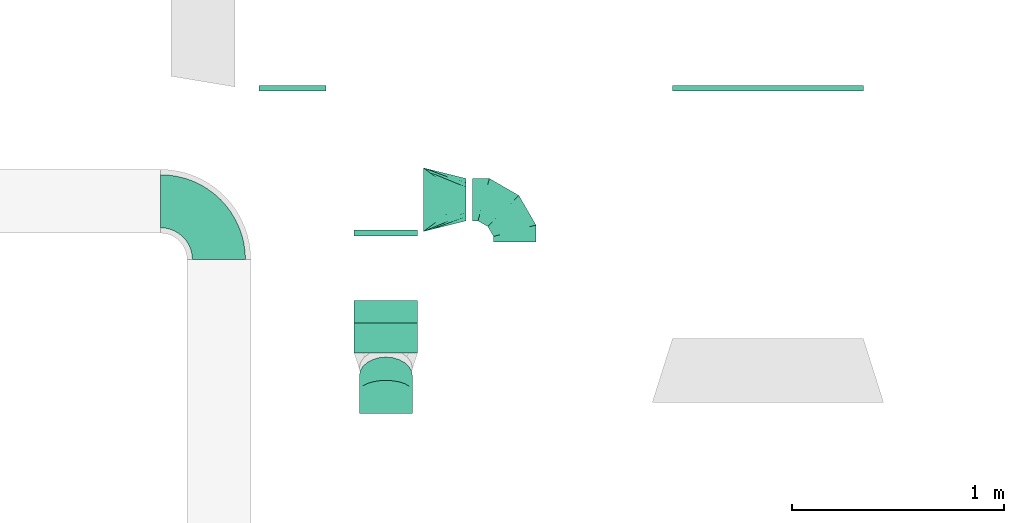
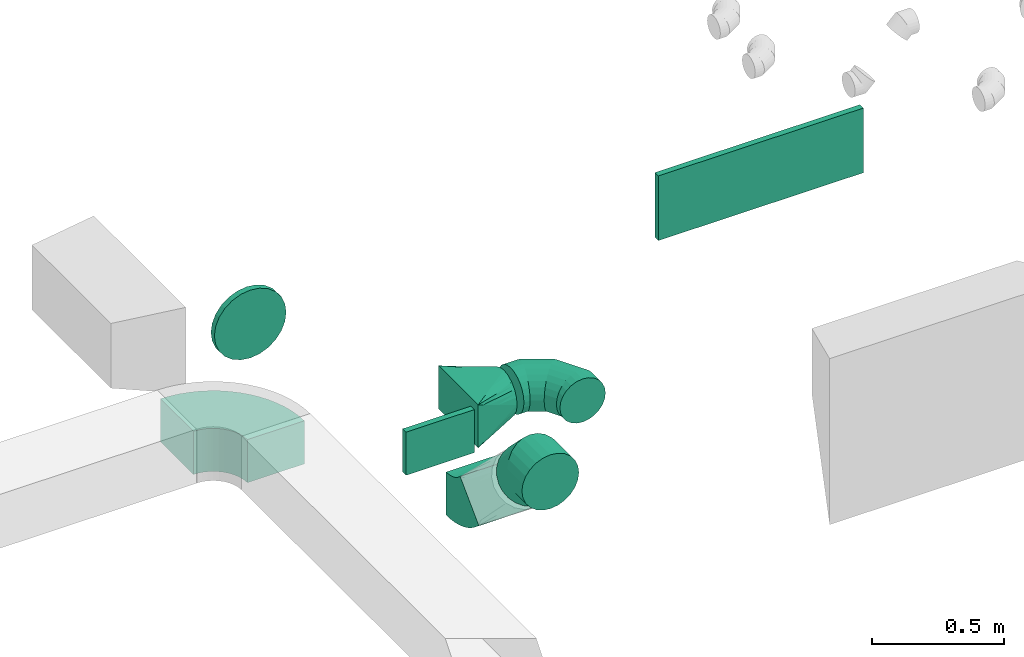
# One storey, part 53 of 62: 8 flow fittings.
"""IFC2X3 building model written with IfcOpenShell, lengths in millimetres."""

from ifc_helpers import new_model, entity, si_unit, converted_unit, derived_unit, direction, frame, frame_2d, origin, origin_2d_with_axis, place, context, subcontext, project, spatial, polyline, circle_curve, parameter, trimmed, segment, composite_curve, rectangle, outline, extrude, faceted_brep, source, transform, mapped, material, type_object, type_shapes, element, save


model = new_model("IFC2X3")

# Units and contexts
model_context = context("Model", 3, precision=0.01, world=origin(), true_north=direction((6.12303176911189e-17, 1.0)))
body_context = subcontext(model_context, "Body", "Model", "MODEL_VIEW")
ifc_project = project(units=[si_unit("LENGTHUNIT", "METRE", prefix="MILLI"), si_unit("AREAUNIT", "SQUARE_METRE"), si_unit("VOLUMEUNIT", "CUBIC_METRE"), converted_unit("PLANEANGLEUNIT", "DEGREE", entity("IfcRatioMeasure", 0.0174532925199433), si_unit("PLANEANGLEUNIT", "RADIAN"), dimensions=[0, 0, 0, 0, 0, 0, 0]), si_unit("MASSUNIT", "GRAM", prefix="KILO"), derived_unit("MASSDENSITYUNIT", [(si_unit("MASSUNIT", "GRAM", prefix="KILO"), 1), (si_unit("LENGTHUNIT", "METRE"), -3)]), derived_unit("MOMENTOFINERTIAUNIT", [(si_unit("LENGTHUNIT", "METRE"), 4)]), si_unit("TIMEUNIT", "SECOND"), si_unit("FREQUENCYUNIT", "HERTZ"), si_unit("THERMODYNAMICTEMPERATUREUNIT", "DEGREE_CELSIUS"), derived_unit("THERMALTRANSMITTANCEUNIT", [(si_unit("MASSUNIT", "GRAM", prefix="KILO"), 1), (si_unit("THERMODYNAMICTEMPERATUREUNIT", "KELVIN"), -1), (si_unit("TIMEUNIT", "SECOND"), -3)]), derived_unit("VOLUMETRICFLOWRATEUNIT", [(si_unit("LENGTHUNIT", "METRE"), 3), (si_unit("TIMEUNIT", "SECOND"), -1)]), derived_unit("MASSFLOWRATEUNIT", [(si_unit("MASSUNIT", "GRAM", prefix="KILO"), 1), (si_unit("TIMEUNIT", "SECOND"), -1)]), derived_unit("ROTATIONALFREQUENCYUNIT", [(si_unit("TIMEUNIT", "SECOND"), -1)]), si_unit("ELECTRICCURRENTUNIT", "AMPERE"), si_unit("ELECTRICVOLTAGEUNIT", "VOLT"), si_unit("POWERUNIT", "WATT"), si_unit("FORCEUNIT", "NEWTON", prefix="KILO"), si_unit("ILLUMINANCEUNIT", "LUX"), si_unit("LUMINOUSFLUXUNIT", "LUMEN"), si_unit("LUMINOUSINTENSITYUNIT", "CANDELA"), derived_unit("USERDEFINED", [(si_unit("MASSUNIT", "GRAM", prefix="KILO"), -1), (si_unit("LENGTHUNIT", "METRE"), -2), (si_unit("TIMEUNIT", "SECOND"), 3), (si_unit("LUMINOUSFLUXUNIT", "LUMEN"), 1)]), derived_unit("LINEARVELOCITYUNIT", [(si_unit("LENGTHUNIT", "METRE"), 1), (si_unit("TIMEUNIT", "SECOND"), -1)]), si_unit("PRESSUREUNIT", "PASCAL"), derived_unit("USERDEFINED", [(si_unit("LENGTHUNIT", "METRE"), -2), (si_unit("MASSUNIT", "GRAM", prefix="KILO"), 1), (si_unit("TIMEUNIT", "SECOND"), -2)]), derived_unit("LINEARFORCEUNIT", [(si_unit("MASSUNIT", "GRAM", prefix="KILO"), 1), (si_unit("LENGTHUNIT", "METRE"), 1), (si_unit("TIMEUNIT", "SECOND"), -2), (si_unit("LENGTHUNIT", "METRE"), -1)]), derived_unit("PLANARFORCEUNIT", [(si_unit("MASSUNIT", "GRAM", prefix="KILO"), 1), (si_unit("LENGTHUNIT", "METRE"), 1), (si_unit("TIMEUNIT", "SECOND"), -2), (si_unit("LENGTHUNIT", "METRE"), -2)])], contexts=[model_context])

# Site, building, storey
site_placement = place(None, origin())
site = spatial("IfcSite", under=ifc_project, at=site_placement, CompositionType="ELEMENT")
building_placement = place(site_placement, origin())
building = spatial("IfcBuilding", under=site, at=building_placement, CompositionType="ELEMENT")
storey_placement = place(building_placement, frame((0.0, 0.0, 24000.0)))
storey = spatial("IfcBuildingStorey", under=building, at=storey_placement, CompositionType="ELEMENT", Elevation=24000.0)

# Flow fittings
ifc_material = material()
duct_fitting_type_1 = type_object("IfcDuctFittingType", PredefinedType="NOTDEFINED", material=ifc_material)
shared_shape_1 = source(origin(), body_context, "Body", "SweptSolid", [
    extrude(rectangle(XDim=300.0, YDim=26.096, at=origin_2d_with_axis()), frame((6.95, 0.0, -100.0), z_axis=(0.0, 0.0, 1.0), x_axis=(0.0, -1.0, 0.0)), (0.0, 0.0, 1.0), 200.0),
])
type_shapes(duct_fitting_type_1, [shared_shape_1])
flow_fitting_1_placement = place(storey_placement, frame((68503.02, 8732.41, 3300.0), z_axis=(0.0, 0.0, -1.0), x_axis=(0.0, -1.0, 0.0)))
element("IfcFlowFitting", 1, at=flow_fitting_1_placement, inside=storey, type_object=duct_fitting_type_1, material=ifc_material, context=body_context, shape_type="MappedRepresentation", body=[
    mapped(shared_shape_1, transform((0.0, 0.0, 0.0), scale=1.0)),
])
duct_fitting_type_2 = type_object("IfcDuctFittingType", PredefinedType="NOTDEFINED", material=ifc_material)
shared_shape_2 = source(origin(), body_context, "Body", "SweptSolid", [
    extrude(rectangle(XDim=26.0960000001021, YDim=900.0, at=origin_2d_with_axis()), frame((6.95, 0.0, -150.0)), (0.0, 0.0, 1.0), 300.0),
])
type_shapes(duct_fitting_type_2, [shared_shape_2])
flow_fitting_2_placement = place(storey_placement, frame((70303.15, 9413.98, 3500.0), z_axis=(0.0, 0.0, -1.0), x_axis=(0.0, -1.0, 0.0)))
element("IfcFlowFitting", 2, at=flow_fitting_2_placement, inside=storey, type_object=duct_fitting_type_2, material=ifc_material, context=body_context, shape_type="MappedRepresentation", body=[
    mapped(shared_shape_2, transform((0.0, 0.0, 0.0), scale=1.0)),
])
duct_fitting_type_3 = type_object("IfcDuctFittingType", PredefinedType="NOTDEFINED", material=ifc_material)
shared_shape_3 = source(origin(), body_context, "Body", "Brep", [
    faceted_brep([(-200.0, 0.0, -100.0), (-200.0, -25.88, -96.59), (-200.0, -50.0, -86.6), (-200.0, -70.71, -70.71), (-200.0, -86.6, -50.0), (-200.0, -96.59, -25.88), (-200.0, -100.0, 0.0), (-200.0, -96.59, 25.88), (-200.0, -86.6, 50.0), (-200.0, -70.71, 70.71), (-200.0, -50.0, 86.6), (-200.0, -25.88, 96.59), (-200.0, 0.0, 100.0), (-200.0, 25.88, 96.59), (-200.0, 50.0, 86.6), (-200.0, 70.71, 70.71), (-200.0, 86.6, 50.0), (-200.0, 96.59, 25.88), (-200.0, 100.0, 0.0), (-200.0, 96.59, -25.88), (-200.0, 86.6, -50.0), (-200.0, 70.71, -70.71), (-200.0, 50.0, -86.6), (-200.0, 25.88, -96.59), (-153.35, 25.88, 96.59), (-159.81, 50.0, 86.6), (-146.41, 0.0, 100.0), (-165.36, 70.71, 70.71), (-172.29, 96.59, 25.88), (-173.21, 100.0, 0.0), (-169.62, 86.6, 50.0), (-169.62, 86.6, -50.0), (-165.36, 70.71, -70.71), (-172.29, 96.59, -25.88), (-153.35, 25.88, -96.59), (-146.41, 0.0, -100.0), (-159.81, 50.0, -86.6), (-139.48, -25.88, -96.59), (-133.01, -50.0, -86.6), (-127.46, -70.71, -70.71), (-123.21, -86.6, -50.0), (-120.53, -96.59, -25.88), (-119.62, -100.0, 0.0), (-120.53, -96.59, 25.88), (-123.21, -86.6, 50.0), (-127.46, -70.71, 70.71), (-133.01, -50.0, 86.6), (-139.48, -25.88, 96.59), (-72.54, 72.54, 96.59), (-90.19, 90.19, 86.6), (-53.59, 53.59, 100.0), (-105.35, 105.35, 70.71), (-116.99, 116.99, 50.0), (-124.3, 124.3, 25.88), (-126.79, 126.79, 0.0), (-124.3, 124.3, -25.88), (-116.99, 116.99, -50.0), (-105.35, 105.35, -70.71), (-72.54, 72.54, -96.59), (-53.59, 53.59, -100.0), (-90.19, 90.19, -86.6), (-34.64, 34.64, -96.59), (-16.99, 16.99, -86.6), (-1.83, 1.83, -70.71), (9.81, -9.81, -50.0), (17.12, -17.12, -25.88), (19.62, -19.62, 0.0), (17.12, -17.12, 25.88), (9.81, -9.81, 50.0), (-1.83, 1.83, 70.71), (-16.99, 16.99, 86.6), (-34.64, 34.64, 96.59), (-25.88, 153.35, 96.59), (-50.0, 159.81, 86.6), (0.0, 146.41, 100.0), (-70.71, 165.36, 70.71), (-86.6, 169.62, 50.0), (-96.59, 172.29, 25.88), (-100.0, 173.21, 0.0), (-96.59, 172.29, -25.88), (-86.6, 169.62, -50.0), (-70.71, 165.36, -70.71), (-25.88, 153.35, -96.59), (0.0, 146.41, -100.0), (-50.0, 159.81, -86.6), (25.88, 139.48, -96.59), (50.0, 133.01, -86.6), (70.71, 127.46, -70.71), (86.6, 123.21, -50.0), (96.59, 120.53, -25.88), (100.0, 119.62, 0.0), (96.59, 120.53, 25.88), (86.6, 123.21, 50.0), (70.71, 127.46, 70.71), (50.0, 133.01, 86.6), (25.88, 139.48, 96.59), (-25.88, 200.0, -96.59), (-50.0, 200.0, -86.6), (-70.71, 200.0, -70.71), (-86.6, 200.0, -50.0), (-96.59, 200.0, -25.88), (-100.0, 200.0, 0.0), (-96.59, 200.0, 25.88), (-86.6, 200.0, 50.0), (-70.71, 200.0, 70.71), (-50.0, 200.0, 86.6), (-25.88, 200.0, 96.59), (0.0, 200.0, 100.0), (25.88, 200.0, 96.59), (50.0, 200.0, 86.6), (70.71, 200.0, 70.71), (86.6, 200.0, 50.0), (96.59, 200.0, 25.88), (100.0, 200.0, 0.0), (96.59, 200.0, -25.88), (86.6, 200.0, -50.0), (70.71, 200.0, -70.71), (50.0, 200.0, -86.6), (25.88, 200.0, -96.59), (0.0, 200.0, -100.0)], [[[0, 1, 2, 3, 4, 5, 6, 7, 8, 9, 10, 11, 12, 13, 14, 15, 16, 17, 18, 19, 20, 21, 22, 23]], [[24, 25, 14, 13]], [[26, 24, 13, 12]], [[14, 25, 27, 15]], [[28, 29, 18, 17]], [[30, 28, 17, 16]], [[15, 27, 30, 16]], [[20, 31, 32, 21]], [[33, 31, 20, 19]], [[18, 29, 33, 19]], [[34, 35, 0, 23]], [[36, 34, 23, 22]], [[32, 36, 22, 21]], [[1, 0, 35, 37]], [[2, 1, 37, 38]], [[38, 39, 3, 2]], [[5, 4, 40, 41]], [[6, 5, 41, 42]], [[39, 40, 4, 3]], [[6, 42, 43, 7]], [[7, 43, 44, 8]], [[8, 44, 45, 9]], [[9, 45, 46, 10]], [[10, 46, 47, 11]], [[26, 12, 11, 47]], [[48, 49, 25, 24]], [[50, 48, 24, 26]], [[27, 25, 49, 51]], [[52, 53, 28, 30]], [[51, 52, 30, 27]], [[29, 28, 53, 54]], [[55, 56, 31, 33]], [[54, 55, 33, 29]], [[32, 31, 56, 57]], [[58, 59, 35, 34]], [[60, 58, 34, 36]], [[57, 60, 36, 32]], [[37, 35, 59, 61]], [[38, 37, 61, 62]], [[39, 38, 62, 63]], [[41, 40, 64, 65]], [[42, 41, 65, 66]], [[63, 64, 40, 39]], [[43, 42, 66, 67]], [[44, 43, 67, 68]], [[68, 69, 45, 44]], [[46, 45, 69, 70]], [[47, 46, 70, 71]], [[26, 47, 71, 50]], [[72, 73, 49, 48]], [[74, 72, 48, 50]], [[51, 49, 73, 75]], [[76, 77, 53, 52]], [[75, 76, 52, 51]], [[54, 53, 77, 78]], [[79, 80, 56, 55]], [[78, 79, 55, 54]], [[57, 56, 80, 81]], [[82, 83, 59, 58]], [[84, 82, 58, 60]], [[81, 84, 60, 57]], [[61, 59, 83, 85]], [[62, 61, 85, 86]], [[63, 62, 86, 87]], [[65, 64, 88, 89]], [[66, 65, 89, 90]], [[87, 88, 64, 63]], [[67, 66, 90, 91]], [[68, 67, 91, 92]], [[92, 93, 69, 68]], [[70, 69, 93, 94]], [[71, 70, 94, 95]], [[50, 71, 95, 74]], [[96, 97, 98, 99, 100, 101, 102, 103, 104, 105, 106, 107, 108, 109, 110, 111, 112, 113, 114, 115, 116, 117, 118, 119]], [[72, 74, 107, 106]], [[73, 72, 106, 105]], [[75, 73, 105, 104]], [[102, 101, 78, 77]], [[103, 102, 77, 76]], [[75, 104, 103, 76]], [[78, 101, 100, 79]], [[79, 100, 99, 80]], [[80, 99, 98, 81]], [[84, 97, 96, 82]], [[82, 96, 119, 83]], [[84, 81, 98, 97]], [[118, 117, 86, 85]], [[119, 118, 85, 83]], [[116, 87, 86, 117]], [[88, 115, 114, 89]], [[89, 114, 113, 90]], [[115, 88, 87, 116]], [[91, 90, 113, 112]], [[92, 91, 112, 111]], [[111, 110, 93, 92]], [[95, 94, 109, 108]], [[74, 95, 108, 107]], [[110, 109, 94, 93]]]),
])
type_shapes(duct_fitting_type_3, [shared_shape_3])
flow_fitting_3_placement = place(storey_placement, frame((69110.52, 8882.41, 3300.0), z_axis=(0.0, 0.0, 1.0), x_axis=(0.0, 1.0, 0.0)))
element("IfcFlowFitting", 3, at=flow_fitting_3_placement, inside=storey, type_object=duct_fitting_type_3, material=ifc_material, context=body_context, shape_type="MappedRepresentation", body=[
    mapped(shared_shape_3, transform((0.0, 0.0, 0.0), scale=1.0)),
])
duct_fitting_type_4 = type_object("IfcDuctFittingType", PredefinedType="NOTDEFINED", material=ifc_material)
shared_shape_4 = source(origin(), body_context, "Body", "Brep", [
    faceted_brep([(200.0, 30.9, 95.11), (200.0, 19.08, 96.98), (200.0, 9.54, 98.49), (200.0, 4.77, 99.24), (200.0, 0.0, 100.0), (200.0, -4.77, 99.24), (200.0, -9.54, 98.49), (200.0, -19.08, 96.98), (200.0, -30.9, 95.11), (200.0, -44.84, 88.0), (200.0, -58.78, 80.9), (200.0, -69.84, 69.84), (200.0, -80.9, 58.78), (200.0, -88.0, 44.84), (200.0, -95.11, 30.9), (200.0, -96.98, 19.08), (200.0, -98.49, 9.54), (200.0, -99.24, 4.77), (200.0, -100.0, 0.0), (200.0, -99.24, -4.77), (200.0, -98.49, -9.54), (200.0, -96.98, -19.08), (200.0, -95.11, -30.9), (200.0, -88.0, -44.84), (200.0, -80.9, -58.78), (200.0, -69.84, -69.84), (200.0, -58.78, -80.9), (200.0, -44.84, -88.0), (200.0, -30.9, -95.11), (200.0, -19.08, -96.98), (200.0, -9.54, -98.49), (200.0, -4.77, -99.24), (200.0, 0.0, -100.0), (200.0, 4.77, -99.24), (200.0, 9.54, -98.49), (200.0, 19.08, -96.98), (200.0, 30.9, -95.11), (200.0, 44.84, -88.0), (200.0, 58.78, -80.9), (200.0, 69.84, -69.84), (200.0, 80.9, -58.78), (200.0, 88.0, -44.84), (200.0, 95.11, -30.9), (200.0, 96.98, -19.08), (200.0, 98.49, -9.54), (200.0, 99.24, -4.77), (200.0, 100.0, 0.0), (200.0, 99.24, 4.77), (200.0, 98.49, 9.54), (200.0, 96.98, 19.08), (200.0, 95.11, 30.9), (200.0, 88.0, 44.84), (200.0, 80.9, 58.78), (200.0, 69.84, 69.84), (200.0, 58.78, 80.9), (200.0, 44.84, 88.0), (0.0, -150.0, 100.0), (0.0, 150.0, 100.0), (0.0, 150.0, -100.0), (0.0, -150.0, -100.0), (104.11, -71.91, 100.0), (100.0, -108.15, 87.43), (26.03, -130.48, 100.0), (78.09, -91.44, 100.0), (52.06, -110.96, 100.0), (188.01, -8.99, 100.0), (176.03, -17.98, 100.0), (152.06, -35.96, 100.0), (128.09, -53.94, 100.0), (52.06, -136.99, 73.97), (78.09, -130.48, 60.96), (104.11, -123.97, 47.94), (128.09, -117.98, 35.96), (152.06, -111.99, 23.97), (176.03, -105.99, 11.99), (188.01, -103.0, 5.99), (26.03, -143.49, 86.99), (26.03, -143.49, -86.99), (52.06, -136.99, -73.97), (78.09, -130.48, -60.96), (104.11, -123.97, -47.94), (128.09, -117.98, -35.96), (152.06, -111.99, -23.97), (176.03, -105.99, -11.99), (188.01, -103.0, -5.99), (100.0, -112.43, -83.15), (52.06, -110.96, -100.0), (78.09, -91.44, -100.0), (104.11, -71.91, -100.0), (128.09, -53.94, -100.0), (152.06, -35.96, -100.0), (176.03, -17.98, -100.0), (188.01, -8.99, -100.0), (26.03, -130.48, -100.0), (26.03, 130.48, -100.0), (52.06, 110.96, -100.0), (78.09, 91.44, -100.0), (104.11, 71.91, -100.0), (128.09, 53.94, -100.0), (152.06, 35.96, -100.0), (176.03, 17.98, -100.0), (188.01, 8.99, -100.0), (100.0, 108.15, -87.43), (52.06, 136.99, -73.97), (78.09, 130.48, -60.96), (104.11, 123.97, -47.94), (128.09, 117.98, -35.96), (152.06, 111.99, -23.97), (176.03, 105.99, -11.99), (188.01, 103.0, -5.99), (26.03, 143.49, -86.99), (26.03, 143.49, 86.99), (52.06, 136.99, 73.97), (78.09, 130.48, 60.96), (104.11, 123.97, 47.94), (128.09, 117.98, 35.96), (152.06, 111.99, 23.97), (176.03, 105.99, 11.99), (188.01, 103.0, 5.99), (100.0, 112.43, 83.15), (52.06, 110.96, 100.0), (78.09, 91.44, 100.0), (104.11, 71.91, 100.0), (128.09, 53.94, 100.0), (152.06, 35.96, 100.0), (176.03, 17.98, 100.0), (188.01, 8.99, 100.0), (26.03, 130.48, 100.0)], [[[0, 1, 2, 3, 4, 5, 6, 7, 8, 9, 10, 11, 12, 13, 14, 15, 16, 17, 18, 19, 20, 21, 22, 23, 24, 25, 26, 27, 28, 29, 30, 31, 32, 33, 34, 35, 36, 37, 38, 39, 40, 41, 42, 43, 44, 45, 46, 47, 48, 49, 50, 51, 52, 53, 54, 55]], [[56, 57, 58, 59]], [[60, 9, 8]], [[56, 61, 62]], [[9, 60, 63, 64]], [[65, 66, 67, 68, 60, 8, 7, 6, 5, 4]], [[62, 61, 10]], [[13, 69, 70, 71]], [[64, 10, 9]], [[14, 71, 72, 73, 74, 75, 18, 17, 16, 15]], [[12, 76, 69]], [[71, 14, 13]], [[61, 76, 11]], [[10, 64, 62]], [[76, 12, 11]], [[10, 61, 11]], [[61, 56, 76]], [[69, 13, 12]], [[75, 74, 73, 72, 71, 70, 69, 76, 56, 59, 77, 78, 79, 80, 81, 82, 83, 84, 18]], [[80, 23, 22]], [[59, 85, 77]], [[23, 80, 79, 78]], [[84, 83, 82, 81, 80, 22, 21, 20, 19, 18]], [[77, 85, 24]], [[27, 86, 87, 88]], [[78, 24, 23]], [[28, 88, 89, 90, 91, 92, 32, 31, 30, 29]], [[26, 93, 86]], [[88, 28, 27]], [[85, 93, 25]], [[24, 78, 77]], [[93, 26, 25]], [[24, 85, 25]], [[85, 59, 93]], [[86, 27, 26]], [[92, 91, 90, 89, 88, 87, 86, 93, 59, 58, 94, 95, 96, 97, 98, 99, 100, 101, 32]], [[97, 37, 36]], [[58, 102, 94]], [[37, 97, 96, 95]], [[101, 100, 99, 98, 97, 36, 35, 34, 33, 32]], [[94, 102, 38]], [[41, 103, 104, 105]], [[95, 38, 37]], [[42, 105, 106, 107, 108, 109, 46, 45, 44, 43]], [[40, 110, 103]], [[105, 42, 41]], [[102, 110, 39]], [[38, 95, 94]], [[110, 40, 39]], [[38, 102, 39]], [[102, 58, 110]], [[103, 41, 40]], [[58, 57, 111, 112, 113, 114, 115, 116, 117, 118, 46, 109, 108, 107, 106, 105, 104, 103, 110]], [[114, 51, 50]], [[57, 119, 111]], [[51, 114, 113, 112]], [[118, 117, 116, 115, 114, 50, 49, 48, 47, 46]], [[111, 119, 52]], [[55, 120, 121, 122]], [[112, 52, 51]], [[0, 122, 123, 124, 125, 126, 4, 3, 2, 1]], [[54, 127, 120]], [[122, 0, 55]], [[119, 127, 53]], [[52, 112, 111]], [[127, 54, 53]], [[52, 119, 53]], [[119, 57, 127]], [[120, 55, 54]], [[57, 56, 62, 64, 63, 60, 68, 67, 66, 65, 4, 126, 125, 124, 123, 122, 121, 120, 127]]]),
])
type_shapes(duct_fitting_type_4, [shared_shape_4])
flow_fitting_4_placement = place(storey_placement, frame((68680.62, 8882.41, 3300.0)))
element("IfcFlowFitting", 4, at=flow_fitting_4_placement, inside=storey, type_object=duct_fitting_type_4, material=ifc_material, context=body_context, shape_type="MappedRepresentation", body=[
    mapped(shared_shape_4, transform((0.0, 0.0, 0.0), scale=1.0)),
])
duct_fitting_type_5 = type_object("IfcDuctFittingType", PredefinedType="NOTDEFINED", material=ifc_material)
shared_shape_5 = source(origin(), body_context, "Body", "Brep", [
    faceted_brep([(-103.55, 0.0, -125.0), (-103.55, -32.35, -120.74), (-103.55, -62.5, -108.25), (-103.55, -88.39, -88.39), (-103.55, -108.25, -62.5), (-103.55, -120.74, -32.35), (-103.55, -125.0, 0.0), (-103.55, -120.74, 32.35), (-103.55, -108.25, 62.5), (-103.55, -88.39, 88.39), (-103.55, -62.5, 108.25), (-103.55, -32.35, 120.74), (-103.55, 0.0, 125.0), (-103.55, 32.35, 120.74), (-103.55, 62.5, 108.25), (-103.55, 88.39, 88.39), (-103.55, 108.25, 62.5), (-103.55, 120.74, 32.35), (-103.55, 125.0, 0.0), (-103.55, 120.74, -32.35), (-103.55, 108.25, -62.5), (-103.55, 88.39, -88.39), (-103.55, 62.5, -108.25), (-103.55, 32.35, -120.74), (-13.4, 32.35, 120.74), (-25.89, 62.5, 108.25), (0.0, 0.0, 125.0), (-36.61, 88.39, 88.39), (-44.84, 108.25, 62.5), (-50.01, 120.74, 32.35), (-51.78, 125.0, 0.0), (-50.01, 120.74, -32.35), (-44.84, 108.25, -62.5), (-36.61, 88.39, -88.39), (-13.4, 32.35, -120.74), (0.0, 0.0, -125.0), (-25.89, 62.5, -108.25), (13.4, -32.35, -120.74), (25.89, -62.5, -108.25), (36.61, -88.39, -88.39), (44.84, -108.25, -62.5), (50.01, -120.74, -32.35), (51.78, -125.0, 0.0), (50.01, -120.74, 32.35), (44.84, -108.25, 62.5), (36.61, -88.39, 88.39), (25.89, -62.5, 108.25), (13.4, -32.35, 120.74), (73.22, 73.22, 125.0), (50.35, 96.1, 120.74), (29.03, 117.42, 108.25), (10.72, 135.72, 88.39), (-3.32, 149.77, 62.5), (-12.15, 158.6, 32.35), (-15.17, 161.61, 0.0), (-12.15, 158.6, -32.35), (-3.32, 149.77, -62.5), (10.72, 135.72, -88.39), (29.03, 117.42, -108.25), (50.35, 96.1, -120.74), (73.22, 73.22, -125.0), (96.1, 50.35, -120.74), (117.42, 29.03, -108.25), (135.72, 10.72, -88.39), (149.77, -3.32, -62.5), (158.6, -12.15, -32.35), (161.61, -15.17, 0.0), (158.6, -12.15, 32.35), (149.77, -3.32, 62.5), (135.72, 10.72, 88.39), (117.42, 29.03, 108.25), (96.1, 50.35, 120.74)], [[[0, 1, 2, 3, 4, 5, 6, 7, 8, 9, 10, 11, 12, 13, 14, 15, 16, 17, 18, 19, 20, 21, 22, 23]], [[24, 25, 14, 13]], [[26, 24, 13, 12]], [[14, 25, 27, 15]], [[28, 29, 17, 16]], [[28, 16, 15, 27]], [[30, 18, 17, 29]], [[31, 32, 20, 19]], [[30, 31, 19, 18]], [[32, 33, 21, 20]], [[34, 35, 0, 23]], [[36, 34, 23, 22]], [[33, 36, 22, 21]], [[1, 0, 35, 37]], [[2, 1, 37, 38]], [[38, 39, 3, 2]], [[5, 4, 40, 41]], [[6, 5, 41, 42]], [[39, 40, 4, 3]], [[6, 42, 43, 7]], [[7, 43, 44, 8]], [[8, 44, 45, 9]], [[9, 45, 46, 10]], [[10, 46, 47, 11]], [[26, 12, 11, 47]], [[24, 26, 48, 49]], [[25, 24, 49, 50]], [[27, 25, 50, 51]], [[29, 28, 52, 53]], [[30, 29, 53, 54]], [[51, 52, 28, 27]], [[30, 54, 55, 31]], [[31, 55, 56, 32]], [[57, 33, 32, 56]], [[36, 58, 59, 34]], [[34, 59, 60, 35]], [[58, 36, 33, 57]], [[35, 60, 61, 37]], [[37, 61, 62, 38]], [[63, 39, 38, 62]], [[40, 64, 65, 41]], [[41, 65, 66, 42]], [[64, 40, 39, 63]], [[43, 42, 66, 67]], [[44, 43, 67, 68]], [[68, 69, 45, 44]], [[47, 46, 70, 71]], [[26, 47, 71, 48]], [[69, 70, 46, 45]], [[59, 58, 57, 56, 55, 54, 53, 52, 51, 50, 49, 48, 71, 70, 69, 68, 67, 66, 65, 64, 63, 62, 61, 60]]]),
])
type_shapes(duct_fitting_type_5, [shared_shape_5])
flow_fitting_5_placement = place(storey_placement, frame((68503.02, 7979.19, 3625.0), z_axis=(1.0, 0.0, 0.0), x_axis=(0.0, -0.707106781186393, 0.707106781186702)))
element("IfcFlowFitting", 5, at=flow_fitting_5_placement, inside=storey, type_object=duct_fitting_type_5, material=ifc_material, context=body_context, shape_type="MappedRepresentation", body=[
    mapped(shared_shape_5, transform((0.0, 0.0, 0.0), scale=1.0)),
])
duct_fitting_type_6 = type_object("IfcDuctFittingType", PredefinedType="NOTDEFINED", material=ifc_material)
shared_shape_6 = source(origin(), body_context, "Body", "Brep", [
    faceted_brep([(20.0, 0.0, -157.5), (20.0, 40.76, -152.13), (20.0, 78.75, -136.4), (20.0, 111.37, -111.37), (20.0, 136.4, -78.75), (20.0, 152.13, -40.76), (20.0, 157.5, 0.0), (20.0, 152.13, 40.76), (20.0, 136.4, 78.75), (20.0, 111.37, 111.37), (20.0, 78.75, 136.4), (20.0, 40.76, 152.13), (20.0, 0.0, 157.5), (20.0, -40.76, 152.13), (20.0, -78.75, 136.4), (20.0, -111.37, 111.37), (20.0, -136.4, 78.75), (20.0, -152.13, 40.76), (20.0, -157.5, 0.0), (20.0, -152.13, -40.76), (20.0, -136.4, -78.75), (20.0, -111.37, -111.37), (20.0, -78.75, -136.4), (20.0, -40.76, -152.13), (0.0, 0.0, 157.5), (-6.1, 0.0, 157.5), (-6.1, -40.76, 152.13), (0.0, -40.76, 152.13), (-6.1, -78.75, 136.4), (0.0, -78.75, 136.4), (0.0, -111.37, 111.37), (-6.1, -111.37, 111.37), (0.0, -136.4, 78.75), (-6.1, -136.4, 78.75), (-6.1, -152.13, 40.76), (0.0, -152.13, 40.76), (-6.1, -157.5, 0.0), (0.0, -157.5, 0.0), (-6.1, -152.13, -40.76), (0.0, -152.13, -40.76), (-6.1, -136.4, -78.75), (0.0, -136.4, -78.75), (0.0, -111.37, -111.37), (-6.1, -111.37, -111.37), (0.0, 0.0, -157.5), (0.0, -40.76, -152.13), (-6.1, -40.76, -152.13), (-6.1, 0.0, -157.5), (0.0, -78.75, -136.4), (-6.1, -78.75, -136.4), (-6.1, 40.76, -152.13), (0.0, 40.76, -152.13), (-6.1, 78.75, -136.4), (0.0, 78.75, -136.4), (0.0, 111.37, -111.37), (-6.1, 111.37, -111.37), (0.0, 136.4, -78.75), (-6.1, 136.4, -78.75), (-6.1, 152.13, -40.76), (0.0, 152.13, -40.76), (-6.1, 157.5, 0.0), (0.0, 157.5, 0.0), (-6.1, 152.13, 40.76), (0.0, 152.13, 40.76), (-6.1, 136.4, 78.75), (0.0, 136.4, 78.75), (0.0, 111.37, 111.37), (-6.1, 111.37, 111.37), (0.0, 78.75, 136.4), (-6.1, 78.75, 136.4), (-6.1, 40.76, 152.13), (0.0, 40.76, 152.13)], [[[0, 1, 2, 3, 4, 5, 6, 7, 8, 9, 10, 11, 12, 13, 14, 15, 16, 17, 18, 19, 20, 21, 22, 23]], [[13, 12, 24, 25, 26, 27]], [[14, 13, 27, 26, 28, 29]], [[30, 15, 14, 29, 28, 31]], [[17, 16, 32, 33, 34, 35]], [[18, 17, 35, 34, 36, 37]], [[32, 16, 15, 30, 31, 33]], [[19, 18, 37, 36, 38, 39]], [[20, 19, 39, 38, 40, 41]], [[42, 21, 20, 41, 40, 43]], [[44, 0, 23, 45, 46, 47]], [[48, 49, 46, 45, 23, 22]], [[22, 21, 42, 43, 49, 48]], [[1, 0, 44, 47, 50, 51]], [[2, 1, 51, 50, 52, 53]], [[54, 3, 2, 53, 52, 55]], [[5, 4, 56, 57, 58, 59]], [[6, 5, 59, 58, 60, 61]], [[56, 4, 3, 54, 55, 57]], [[7, 6, 61, 60, 62, 63]], [[8, 7, 63, 62, 64, 65]], [[66, 9, 8, 65, 64, 67]], [[11, 10, 68, 69, 70, 71]], [[12, 11, 71, 70, 25, 24]], [[68, 10, 9, 66, 67, 69]], [[46, 49, 43, 40, 38, 36, 34, 33, 31, 28, 26, 25, 70, 69, 67, 64, 62, 60, 58, 57, 55, 52, 50, 47]]]),
])
type_shapes(duct_fitting_type_6, [shared_shape_6])
flow_fitting_6_placement = place(storey_placement, frame((68062.74, 9413.98, 3590.0), z_axis=(0.0, 0.0, -1.0), x_axis=(0.0, -1.0, 0.0)))
element("IfcFlowFitting", 6, at=flow_fitting_6_placement, inside=storey, type_object=duct_fitting_type_6, material=ifc_material, context=body_context, shape_type="MappedRepresentation", body=[
    mapped(shared_shape_6, transform((0.0, 0.0, 0.0), scale=1.0)),
])
duct_fitting_type_7 = type_object("IfcDuctFittingType", PredefinedType="NOTDEFINED", material=ifc_material)
shared_shape_7 = source(origin(), body_context, "Body", "SweptSolid", [
    extrude(outline(composite_curve([segment(polyline([(-262.5, -137.5), (-12.5, -137.5)]), True, "CONTINUOUS"), segment(trimmed(circle_curve(frame_2d((137.5, -137.5), x_axis=(0.0, 1.0)), 150.0), [parameter(0.0)], [parameter(90.0000000000001)], True, "PARAMETER"), False, "CONTINUOUS"), segment(polyline([(137.5, 12.5), (137.5, 262.5)]), True, "CONTINUOUS"), segment(trimmed(circle_curve(frame_2d((137.5, -137.5), x_axis=(0.0, 1.0)), 400.0), [parameter(0.0)], [parameter(90.0000000000001)], True, "PARAMETER"), True, "CONTINUOUS")], self_intersect=False)), frame((-137.5, 137.5, -100.0), z_axis=(0.0, 0.0, 1.0), x_axis=(-1.0, 0.0, 0.0)), (0.0, 0.0, 1.0), 200.0),
])
type_shapes(duct_fitting_type_7, [shared_shape_7])
flow_fitting_7_placement = place(storey_placement, frame((67716.73, 8875.02, 3600.0), z_axis=(0.0, 0.0, 1.0), x_axis=(0.0, 1.0, 0.0)))
element("IfcFlowFitting", 7, at=flow_fitting_7_placement, inside=storey, type_object=duct_fitting_type_7, material=ifc_material, context=body_context, shape_type="MappedRepresentation", body=[
    mapped(shared_shape_7, transform((0.0, 0.0, 0.0), scale=1.0)),
])
duct_fitting_type_8 = type_object("IfcDuctFittingType", PredefinedType="NOTDEFINED", material=ifc_material)
shared_shape_8 = source(origin(), body_context, "Body", "SweptSolid", [
    extrude(outline(composite_curve([segment(polyline([(-136.61, -88.39), (63.39, -88.39)]), True, "CONTINUOUS"), segment(trimmed(circle_curve(frame_2d((213.39, -88.39), x_axis=(-0.707106781186546, 0.707106781186546)), 150.0), [parameter(0.0)], [parameter(45.0)], True, "PARAMETER"), False, "CONTINUOUS"), segment(polyline([(107.32, 17.68), (-34.1, 159.1)]), True, "CONTINUOUS"), segment(trimmed(circle_curve(frame_2d((213.39, -88.39), x_axis=(-0.707106781186546, 0.707106781186546)), 350.0), [parameter(0.0)], [parameter(45.0)], True, "PARAMETER"), True, "CONTINUOUS")], self_intersect=False)), frame((-15.17, 36.61, -150.0), z_axis=(0.0, 0.0, 1.0), x_axis=(-0.707106781186547, 0.707106781186548, 0.0)), (0.0, 0.0, 1.0), 300.0),
])
type_shapes(duct_fitting_type_8, [shared_shape_8])
flow_fitting_8_placement = place(storey_placement, frame((68503.02, 8304.19, 3300.0), z_axis=(-1.0, 0.0, 0.0), x_axis=(0.0, -1.0, 0.0)))
element("IfcFlowFitting", 8, at=flow_fitting_8_placement, inside=storey, type_object=duct_fitting_type_8, material=ifc_material, context=body_context, shape_type="MappedRepresentation", body=[
    mapped(shared_shape_8, transform((0.0, 0.0, 0.0), scale=1.0)),
])

save(model, "model.ifc")
